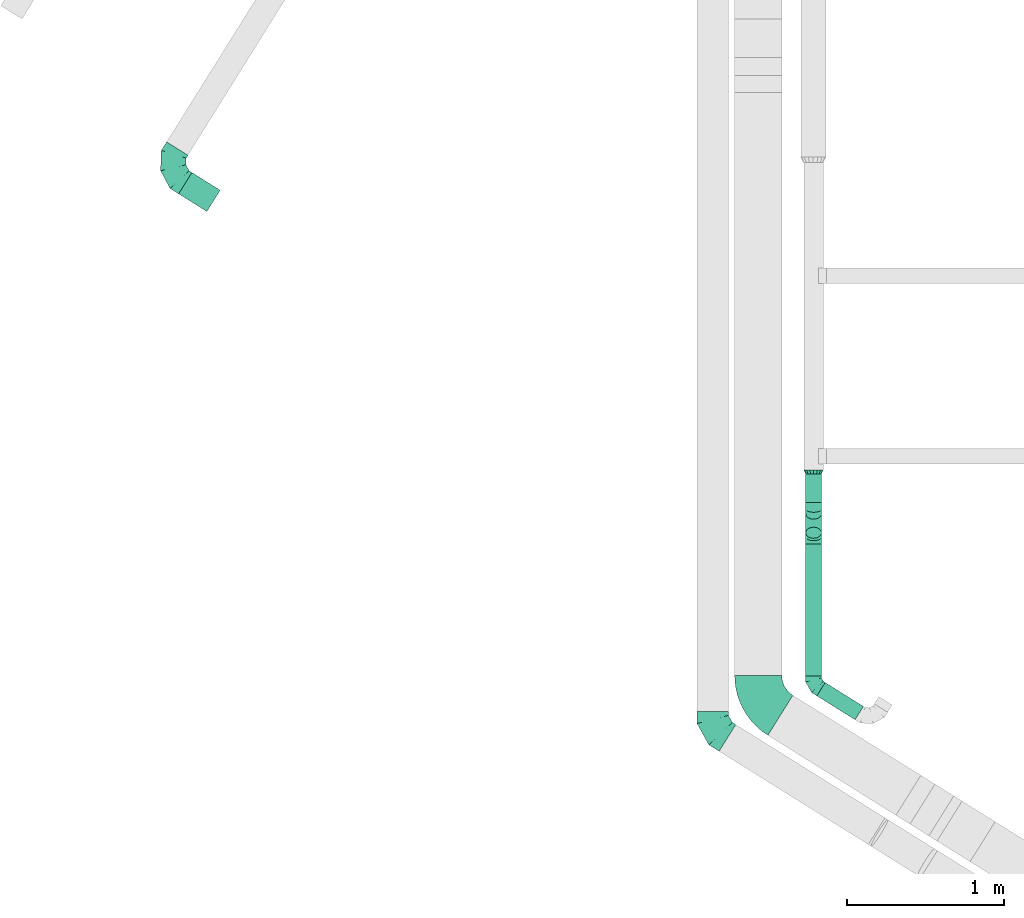
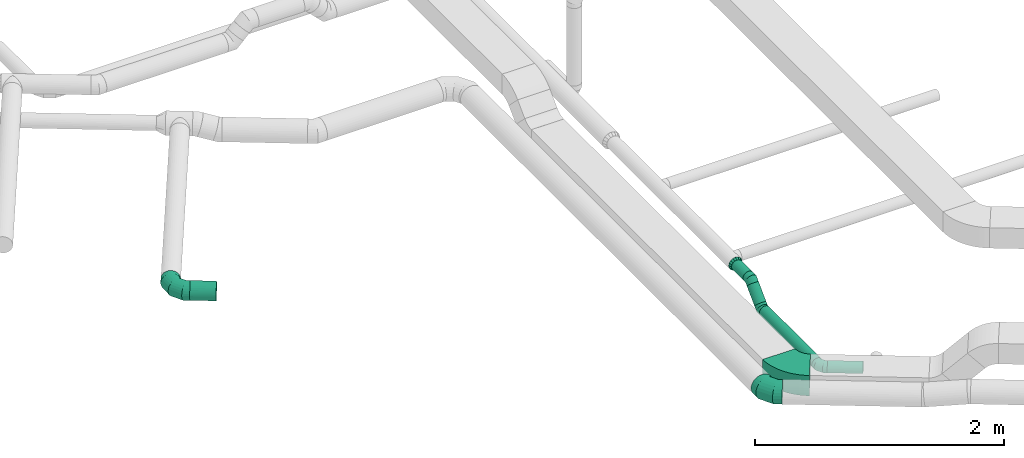
# One storey, part 4 of 60: 7 flow fittings, 5 flow segments.
"""IFC2X3 building model written with IfcOpenShell, lengths in millimetres."""

from ifc_helpers import new_model, entity, si_unit, converted_unit, derived_unit, direction, frame, frame_2d, origin, origin_2d_with_axis, place, context, subcontext, project, spatial, polyline, circle_curve, parameter, trimmed, segment, composite_curve, circle, outline, extrude, faceted_brep, source, transform, mapped, material, type_object, type_shapes, element, save


model = new_model("IFC2X3")

# Units and contexts
model_context = context("Model", 3, precision=0.01, world=origin(), true_north=direction((6.12303176911189e-17, 1.0)))
body_context = subcontext(model_context, "Body", "Model", "MODEL_VIEW")
ifc_project = project(units=[si_unit("LENGTHUNIT", "METRE", prefix="MILLI"), si_unit("AREAUNIT", "SQUARE_METRE"), si_unit("VOLUMEUNIT", "CUBIC_METRE"), converted_unit("PLANEANGLEUNIT", "DEGREE", entity("IfcRatioMeasure", 0.0174532925199433), si_unit("PLANEANGLEUNIT", "RADIAN"), dimensions=[0, 0, 0, 0, 0, 0, 0]), si_unit("MASSUNIT", "GRAM", prefix="KILO"), derived_unit("MASSDENSITYUNIT", [(si_unit("MASSUNIT", "GRAM", prefix="KILO"), 1), (si_unit("LENGTHUNIT", "METRE"), -3)]), derived_unit("MOMENTOFINERTIAUNIT", [(si_unit("LENGTHUNIT", "METRE"), 4)]), si_unit("TIMEUNIT", "SECOND"), si_unit("FREQUENCYUNIT", "HERTZ"), si_unit("THERMODYNAMICTEMPERATUREUNIT", "DEGREE_CELSIUS"), derived_unit("THERMALTRANSMITTANCEUNIT", [(si_unit("MASSUNIT", "GRAM", prefix="KILO"), 1), (si_unit("THERMODYNAMICTEMPERATUREUNIT", "KELVIN"), -1), (si_unit("TIMEUNIT", "SECOND"), -3)]), derived_unit("VOLUMETRICFLOWRATEUNIT", [(si_unit("LENGTHUNIT", "METRE"), 3), (si_unit("TIMEUNIT", "SECOND"), -1)]), derived_unit("MASSFLOWRATEUNIT", [(si_unit("MASSUNIT", "GRAM", prefix="KILO"), 1), (si_unit("TIMEUNIT", "SECOND"), -1)]), derived_unit("ROTATIONALFREQUENCYUNIT", [(si_unit("TIMEUNIT", "SECOND"), -1)]), si_unit("ELECTRICCURRENTUNIT", "AMPERE"), si_unit("ELECTRICVOLTAGEUNIT", "VOLT"), si_unit("POWERUNIT", "WATT"), si_unit("FORCEUNIT", "NEWTON", prefix="KILO"), si_unit("ILLUMINANCEUNIT", "LUX"), si_unit("LUMINOUSFLUXUNIT", "LUMEN"), si_unit("LUMINOUSINTENSITYUNIT", "CANDELA"), derived_unit("USERDEFINED", [(si_unit("MASSUNIT", "GRAM", prefix="KILO"), -1), (si_unit("LENGTHUNIT", "METRE"), -2), (si_unit("TIMEUNIT", "SECOND"), 3), (si_unit("LUMINOUSFLUXUNIT", "LUMEN"), 1)]), derived_unit("LINEARVELOCITYUNIT", [(si_unit("LENGTHUNIT", "METRE"), 1), (si_unit("TIMEUNIT", "SECOND"), -1)]), si_unit("PRESSUREUNIT", "PASCAL"), derived_unit("USERDEFINED", [(si_unit("LENGTHUNIT", "METRE"), -2), (si_unit("MASSUNIT", "GRAM", prefix="KILO"), 1), (si_unit("TIMEUNIT", "SECOND"), -2)]), derived_unit("LINEARFORCEUNIT", [(si_unit("MASSUNIT", "GRAM", prefix="KILO"), 1), (si_unit("LENGTHUNIT", "METRE"), 1), (si_unit("TIMEUNIT", "SECOND"), -2), (si_unit("LENGTHUNIT", "METRE"), -1)]), derived_unit("PLANARFORCEUNIT", [(si_unit("MASSUNIT", "GRAM", prefix="KILO"), 1), (si_unit("LENGTHUNIT", "METRE"), 1), (si_unit("TIMEUNIT", "SECOND"), -2), (si_unit("LENGTHUNIT", "METRE"), -2)])], contexts=[model_context])

# Site, building, storey
site_placement = place(None, origin())
site = spatial("IfcSite", under=ifc_project, at=site_placement, CompositionType="ELEMENT")
building_placement = place(site_placement, origin())
building = spatial("IfcBuilding", under=site, at=building_placement, CompositionType="ELEMENT")
storey_placement = place(building_placement, frame((0.0, 0.0, 19800.0)))
storey = spatial("IfcBuildingStorey", under=building, at=storey_placement, CompositionType="ELEMENT", Elevation=19800.0)

# Flow segments
duct_segment_type = type_object("IfcDuctSegmentType", PredefinedType="NOTDEFINED")
flow_segment_1_placement = place(storey_placement, frame((16951.05, 3539.05, 2988.4)))
element("IfcFlowSegment", 1, at=flow_segment_1_placement, inside=storey, type_object=duct_segment_type, context=body_context, shape_type="SweptSolid", body=[
    extrude(circle(Radius=50.0, at=origin_2d_with_axis()), frame((51.6, 0.0, 51.6), z_axis=(0.0, 1.0, 0.0), x_axis=(-1.0, 0.0, 0.0)), (0.0, 0.0, 1.0), 840.2093082432),
])
flow_segment_2_placement = place(storey_placement, frame((17021.57, 3257.99, 2988.4)))
element("IfcFlowSegment", 2, at=flow_segment_2_placement, inside=storey, type_object=duct_segment_type, context=body_context, shape_type="SweptSolid", body=[
    extrude(circle(Radius=50.0, at=origin_2d_with_axis()), frame((271.75, 44.0, 51.6), z_axis=(-0.848052743777585, 0.529911826412008, 0.0), x_axis=(-0.529911826412008, -0.848052743777585, 0.0)), (0.0, 0.0, 1.0), 287.312124453277),
])
flow_segment_3_placement = place(storey_placement, frame((16951.05, 4413.02, 3032.34)))
element("IfcFlowSegment", 3, at=flow_segment_3_placement, inside=storey, type_object=duct_segment_type, context=body_context, shape_type="SweptSolid", body=[
    extrude(circle(Radius=50.0, at=origin_2d_with_axis()), frame((51.6, 36.95, 36.95), z_axis=(0.0, 0.707106781186553, 0.707106781186542), x_axis=(1.0, 0.0, 0.0)), (0.0, 0.0, 1.0), 171.715728752511),
])
flow_segment_4_placement = place(storey_placement, frame((16951.05, 4642.1, 3168.4)))
element("IfcFlowSegment", 4, at=flow_segment_4_placement, inside=storey, type_object=duct_segment_type, context=body_context, shape_type="SweptSolid", body=[
    extrude(circle(Radius=50.0, at=origin_2d_with_axis()), frame((51.6, 0.0, 51.6), z_axis=(0.0, 1.0, 0.0), x_axis=(-1.0, 0.0, 0.0)), (0.0, 0.0, 1.0), 183.078643762733),
])
flow_segment_5_placement = place(storey_placement, frame((12959.43, 6493.1, 3168.4)))
element("IfcFlowSegment", 5, at=flow_segment_5_placement, inside=storey, type_object=duct_segment_type, context=body_context, shape_type="SweptSolid", body=[
    extrude(circle(Radius=80.0, at=origin_2d_with_axis()), frame((43.99, 181.83, 81.6), z_axis=(0.84805274377758, -0.529911826412016, 0.0), x_axis=(-0.529911826412016, -0.84805274377758, 0.0)), (0.0, 0.0, 1.0), 212.089328759062),
])

# Flow fittings
ifc_material = material()
duct_fitting_type_1 = type_object("IfcDuctFittingType", PredefinedType="NOTDEFINED", material=ifc_material)
shared_shape_1 = source(origin(), body_context, "Body", "Brep", [
    faceted_brep([(-160.0, 0.0, -80.0), (-160.0, -20.71, -77.27), (-160.0, -40.0, -69.28), (-160.0, -56.57, -56.57), (-160.0, -69.28, -40.0), (-160.0, -77.27, -20.71), (-160.0, -80.0, 0.0), (-160.0, -77.27, 20.71), (-160.0, -69.28, 40.0), (-160.0, -56.57, 56.57), (-160.0, -40.0, 69.28), (-160.0, -20.71, 77.27), (-160.0, 0.0, 80.0), (-160.0, 20.71, 77.27), (-160.0, 40.0, 69.28), (-160.0, 56.57, 56.57), (-160.0, 69.28, 40.0), (-160.0, 77.27, 20.71), (-160.0, 80.0, 0.0), (-160.0, 77.27, -20.71), (-160.0, 69.28, -40.0), (-160.0, 56.57, -56.57), (-160.0, 40.0, -69.28), (-160.0, 20.71, -77.27), (-122.68, 20.71, 77.27), (-127.85, 40.0, 69.28), (-117.13, 0.0, 80.0), (-132.29, 56.57, 56.57), (-137.83, 77.27, 20.71), (-138.56, 80.0, 0.0), (-135.69, 69.28, 40.0), (-135.69, 69.28, -40.0), (-132.29, 56.57, -56.57), (-137.83, 77.27, -20.71), (-122.68, 20.71, -77.27), (-117.13, 0.0, -80.0), (-127.85, 40.0, -69.28), (-111.58, -20.71, -77.27), (-106.41, -40.0, -69.28), (-101.97, -56.57, -56.57), (-98.56, -69.28, -40.0), (-96.42, -77.27, -20.71), (-95.69, -80.0, 0.0), (-96.42, -77.27, 20.71), (-98.56, -69.28, 40.0), (-101.97, -56.57, 56.57), (-106.41, -40.0, 69.28), (-111.58, -20.71, 77.27), (-58.03, 58.03, 77.27), (-72.15, 72.15, 69.28), (-42.87, 42.87, 80.0), (-84.28, 84.28, 56.57), (-93.59, 93.59, 40.0), (-99.44, 99.44, 20.71), (-101.44, 101.44, 0.0), (-99.44, 99.44, -20.71), (-93.59, 93.59, -40.0), (-84.28, 84.28, -56.57), (-58.03, 58.03, -77.27), (-42.87, 42.87, -80.0), (-72.15, 72.15, -69.28), (-27.71, 27.71, -77.27), (-13.59, 13.59, -69.28), (-1.46, 1.46, -56.57), (7.85, -7.85, -40.0), (13.7, -13.7, -20.71), (15.69, -15.69, 0.0), (13.7, -13.7, 20.71), (7.85, -7.85, 40.0), (-1.46, 1.46, 56.57), (-13.59, 13.59, 69.28), (-27.71, 27.71, 77.27), (-20.71, 122.68, 77.27), (-40.0, 127.85, 69.28), (0.0, 117.13, 80.0), (-56.57, 132.29, 56.57), (-69.28, 135.69, 40.0), (-77.27, 137.83, 20.71), (-80.0, 138.56, 0.0), (-77.27, 137.83, -20.71), (-69.28, 135.69, -40.0), (-56.57, 132.29, -56.57), (-20.71, 122.68, -77.27), (0.0, 117.13, -80.0), (-40.0, 127.85, -69.28), (20.71, 111.58, -77.27), (40.0, 106.41, -69.28), (56.57, 101.97, -56.57), (69.28, 98.56, -40.0), (77.27, 96.42, -20.71), (80.0, 95.69, 0.0), (77.27, 96.42, 20.71), (69.28, 98.56, 40.0), (56.57, 101.97, 56.57), (40.0, 106.41, 69.28), (20.71, 111.58, 77.27), (-20.71, 160.0, -77.27), (-40.0, 160.0, -69.28), (-56.57, 160.0, -56.57), (-69.28, 160.0, -40.0), (-77.27, 160.0, -20.71), (-80.0, 160.0, 0.0), (-77.27, 160.0, 20.71), (-69.28, 160.0, 40.0), (-56.57, 160.0, 56.57), (-40.0, 160.0, 69.28), (-20.71, 160.0, 77.27), (0.0, 160.0, 80.0), (20.71, 160.0, 77.27), (40.0, 160.0, 69.28), (56.57, 160.0, 56.57), (69.28, 160.0, 40.0), (77.27, 160.0, 20.71), (80.0, 160.0, 0.0), (77.27, 160.0, -20.71), (69.28, 160.0, -40.0), (56.57, 160.0, -56.57), (40.0, 160.0, -69.28), (20.71, 160.0, -77.27), (0.0, 160.0, -80.0)], [[[0, 1, 2, 3, 4, 5, 6, 7, 8, 9, 10, 11, 12, 13, 14, 15, 16, 17, 18, 19, 20, 21, 22, 23]], [[24, 25, 14, 13]], [[26, 24, 13, 12]], [[14, 25, 27, 15]], [[28, 29, 18, 17]], [[30, 28, 17, 16]], [[15, 27, 30, 16]], [[20, 31, 32, 21]], [[33, 31, 20, 19]], [[18, 29, 33, 19]], [[34, 35, 0, 23]], [[36, 34, 23, 22]], [[32, 36, 22, 21]], [[1, 0, 35, 37]], [[2, 1, 37, 38]], [[3, 2, 38, 39]], [[5, 4, 40, 41]], [[6, 5, 41, 42]], [[39, 40, 4, 3]], [[6, 42, 43, 7]], [[7, 43, 44, 8]], [[8, 44, 45, 9]], [[9, 45, 46, 10]], [[10, 46, 47, 11]], [[26, 12, 11, 47]], [[48, 49, 25, 24]], [[50, 48, 24, 26]], [[27, 25, 49, 51]], [[52, 53, 28, 30]], [[51, 52, 30, 27]], [[29, 28, 53, 54]], [[55, 56, 31, 33]], [[54, 55, 33, 29]], [[32, 31, 56, 57]], [[58, 59, 35, 34]], [[60, 58, 34, 36]], [[57, 60, 36, 32]], [[37, 35, 59, 61]], [[38, 37, 61, 62]], [[39, 38, 62, 63]], [[41, 40, 64, 65]], [[42, 41, 65, 66]], [[63, 64, 40, 39]], [[43, 42, 66, 67]], [[44, 43, 67, 68]], [[68, 69, 45, 44]], [[46, 45, 69, 70]], [[47, 46, 70, 71]], [[26, 47, 71, 50]], [[72, 73, 49, 48]], [[74, 72, 48, 50]], [[51, 49, 73, 75]], [[76, 77, 53, 52]], [[75, 76, 52, 51]], [[54, 53, 77, 78]], [[79, 80, 56, 55]], [[78, 79, 55, 54]], [[57, 56, 80, 81]], [[82, 83, 59, 58]], [[84, 82, 58, 60]], [[81, 84, 60, 57]], [[61, 59, 83, 85]], [[62, 61, 85, 86]], [[63, 62, 86, 87]], [[65, 64, 88, 89]], [[66, 65, 89, 90]], [[87, 88, 64, 63]], [[67, 66, 90, 91]], [[68, 67, 91, 92]], [[92, 93, 69, 68]], [[70, 69, 93, 94]], [[71, 70, 94, 95]], [[50, 71, 95, 74]], [[96, 97, 98, 99, 100, 101, 102, 103, 104, 105, 106, 107, 108, 109, 110, 111, 112, 113, 114, 115, 116, 117, 118, 119]], [[72, 74, 107, 106]], [[73, 72, 106, 105]], [[75, 73, 105, 104]], [[77, 76, 103, 102]], [[78, 77, 102, 101]], [[75, 104, 103, 76]], [[78, 101, 100, 79]], [[79, 100, 99, 80]], [[80, 99, 98, 81]], [[84, 97, 96, 82]], [[82, 96, 119, 83]], [[84, 81, 98, 97]], [[118, 117, 86, 85]], [[119, 118, 85, 83]], [[116, 87, 86, 117]], [[88, 115, 114, 89]], [[89, 114, 113, 90]], [[115, 88, 87, 116]], [[112, 111, 92, 91]], [[113, 112, 91, 90]], [[111, 110, 93, 92]], [[95, 94, 109, 108]], [[74, 95, 108, 107]], [[110, 109, 94, 93]]]),
])
type_shapes(duct_fitting_type_1, [shared_shape_1])
flow_fitting_1_placement = place(storey_placement, frame((12867.73, 6759.71, 3250.0), z_axis=(0.0, 0.0, 1.0), x_axis=(-0.52991182641202, -0.848052743777577, 0.0)))
element("IfcFlowFitting", 6, at=flow_fitting_1_placement, inside=storey, type_object=duct_fitting_type_1, material=ifc_material, context=body_context, shape_type="MappedRepresentation", body=[
    mapped(shared_shape_1, transform((0.0, 0.0, 0.0), scale=1.0)),
])
duct_fitting_type_2 = type_object("IfcDuctFittingType", PredefinedType="NOTDEFINED", material=ifc_material)
shared_shape_2 = source(origin(), body_context, "Body", "Brep", [
    faceted_brep([(-41.42, 0.0, -50.0), (-41.42, -12.94, -48.3), (-41.42, -25.0, -43.3), (-41.42, -35.36, -35.36), (-41.42, -43.3, -25.0), (-41.42, -48.3, -12.94), (-41.42, -50.0, 0.0), (-41.42, -48.3, 12.94), (-41.42, -43.3, 25.0), (-41.42, -35.36, 35.36), (-41.42, -25.0, 43.3), (-41.42, -12.94, 48.3), (-41.42, 0.0, 50.0), (-41.42, 12.94, 48.3), (-41.42, 25.0, 43.3), (-41.42, 35.36, 35.36), (-41.42, 43.3, 25.0), (-41.42, 48.3, 12.94), (-41.42, 50.0, 0.0), (-41.42, 48.3, -12.94), (-41.42, 43.3, -25.0), (-41.42, 35.36, -35.36), (-41.42, 25.0, -43.3), (-41.42, 12.94, -48.3), (-5.36, 12.94, 48.3), (-10.36, 25.0, 43.3), (0.0, 0.0, 50.0), (-14.64, 35.36, 35.36), (-20.0, 48.3, 12.94), (-20.71, 50.0, 0.0), (-17.94, 43.3, 25.0), (-17.94, 43.3, -25.0), (-14.64, 35.36, -35.36), (-20.0, 48.3, -12.94), (-5.36, 12.94, -48.3), (0.0, 0.0, -50.0), (-10.36, 25.0, -43.3), (5.36, -12.94, -48.3), (10.36, -25.0, -43.3), (14.64, -35.36, -35.36), (17.94, -43.3, -25.0), (20.0, -48.3, -12.94), (20.71, -50.0, 0.0), (20.0, -48.3, 12.94), (17.94, -43.3, 25.0), (14.64, -35.36, 35.36), (10.36, -25.0, 43.3), (5.36, -12.94, 48.3), (29.29, 29.29, 50.0), (20.14, 38.44, 48.3), (11.61, 46.97, 43.3), (4.29, 54.29, 35.36), (-1.33, 59.91, 25.0), (-4.86, 63.44, 12.94), (-6.07, 64.64, 0.0), (-4.86, 63.44, -12.94), (-1.33, 59.91, -25.0), (4.29, 54.29, -35.36), (11.61, 46.97, -43.3), (20.14, 38.44, -48.3), (29.29, 29.29, -50.0), (38.44, 20.14, -48.3), (46.97, 11.61, -43.3), (54.29, 4.29, -35.36), (59.91, -1.33, -25.0), (63.44, -4.86, -12.94), (64.64, -6.07, 0.0), (63.44, -4.86, 12.94), (59.91, -1.33, 25.0), (54.29, 4.29, 35.36), (46.97, 11.61, 43.3), (38.44, 20.14, 48.3)], [[[0, 1, 2, 3, 4, 5, 6, 7, 8, 9, 10, 11, 12, 13, 14, 15, 16, 17, 18, 19, 20, 21, 22, 23]], [[24, 25, 14, 13]], [[26, 24, 13, 12]], [[14, 25, 27, 15]], [[28, 29, 18, 17]], [[30, 28, 17, 16]], [[16, 15, 27, 30]], [[20, 31, 32, 21]], [[33, 31, 20, 19]], [[18, 29, 33, 19]], [[34, 35, 0, 23]], [[36, 34, 23, 22]], [[32, 36, 22, 21]], [[1, 0, 35, 37]], [[2, 1, 37, 38]], [[38, 39, 3, 2]], [[5, 4, 40, 41]], [[6, 5, 41, 42]], [[39, 40, 4, 3]], [[6, 42, 43, 7]], [[7, 43, 44, 8]], [[8, 44, 45, 9]], [[9, 45, 46, 10]], [[10, 46, 47, 11]], [[26, 12, 11, 47]], [[24, 26, 48, 49]], [[25, 24, 49, 50]], [[27, 25, 50, 51]], [[28, 30, 52, 53]], [[29, 28, 53, 54]], [[27, 51, 52, 30]], [[29, 54, 55, 33]], [[33, 55, 56, 31]], [[31, 56, 57, 32]], [[36, 58, 59, 34]], [[34, 59, 60, 35]], [[36, 32, 57, 58]], [[61, 62, 38, 37]], [[60, 61, 37, 35]], [[63, 39, 38, 62]], [[40, 64, 65, 41]], [[41, 65, 66, 42]], [[64, 40, 39, 63]], [[43, 42, 66, 67]], [[44, 43, 67, 68]], [[68, 69, 45, 44]], [[47, 46, 70, 71]], [[26, 47, 71, 48]], [[69, 70, 46, 45]], [[59, 58, 57, 56, 55, 54, 53, 52, 51, 50, 49, 48, 71, 70, 69, 68, 67, 66, 65, 64, 63, 62, 61, 60]]]),
])
type_shapes(duct_fitting_type_2, [shared_shape_2])
for number, where, z_axis, x_axis in (
    (7, (17002.65, 4420.68, 3040.0), (1.0, 0.0, 0.0), (0.0, 1.0, 0.0)),
    (8, (17002.65, 4600.68, 3220.0), (-1.0, 0.0, 0.0), (0.0, 0.707106781186472, 0.707106781186623)),
):
    element("IfcFlowFitting", number, at=place(storey_placement, frame(where, z_axis=z_axis, x_axis=x_axis)), inside=storey, type_object=duct_fitting_type_2, material=ifc_material, context=body_context, shape_type="MappedRepresentation", body=[
        mapped(shared_shape_2, transform((0.0, 0.0, 0.0), scale=1.0)),
    ])
duct_fitting_type_3 = type_object("IfcDuctFittingType", PredefinedType="NOTDEFINED", material=ifc_material)
shared_shape_3 = source(origin(), body_context, "Body", "Brep", [
    faceted_brep([(25.0, -46.19, 19.13), (25.0, -48.1, 9.57), (25.0, -50.0, 0.0), (25.0, -48.1, -9.57), (25.0, -46.19, -19.13), (25.0, -40.77, -27.24), (25.0, -35.36, -35.36), (25.0, -27.24, -40.77), (25.0, -19.13, -46.19), (25.0, -9.57, -48.1), (25.0, 0.0, -50.0), (25.0, 9.57, -48.1), (25.0, 19.13, -46.19), (25.0, 27.24, -40.77), (25.0, 35.36, -35.36), (25.0, 40.77, -27.24), (25.0, 46.19, -19.13), (25.0, 48.1, -9.57), (25.0, 50.0, 0.0), (25.0, 48.1, 9.57), (25.0, 46.19, 19.13), (25.0, 40.77, 27.24), (25.0, 35.36, 35.36), (25.0, 27.24, 40.77), (25.0, 19.13, 46.19), (25.0, 9.57, 48.1), (25.0, 0.0, 50.0), (25.0, -9.57, 48.1), (25.0, -19.13, 46.19), (25.0, -27.24, 40.77), (25.0, -35.36, 35.36), (25.0, -40.77, 27.24), (0.0, -62.5, 0.0), (0.0, -60.02, 12.45), (0.0, -57.74, 23.92), (0.0, -50.97, 34.06), (0.0, -44.19, 44.19), (0.0, -34.06, 50.97), (0.0, -23.92, 57.74), (0.0, -12.45, 60.02), (0.0, 0.0, 62.5), (0.0, 12.45, 60.02), (0.0, 23.92, 57.74), (0.0, 34.06, 50.97), (0.0, 44.19, 44.19), (0.0, 50.97, 34.06), (0.0, 57.74, 23.92), (0.0, 60.02, 12.45), (0.0, 62.5, 0.0), (0.0, 60.02, -12.45), (0.0, 57.74, -23.92), (0.0, 50.97, -34.06), (0.0, 44.19, -44.19), (0.0, 34.06, -50.97), (0.0, 23.92, -57.74), (0.0, 12.45, -60.02), (0.0, 0.0, -62.5), (0.0, -12.45, -60.02), (0.0, -23.92, -57.74), (0.0, -34.06, -50.97), (0.0, -44.19, -44.19), (0.0, -50.97, -34.06), (0.0, -57.74, -23.92), (0.0, -60.02, -12.45)], [[[0, 1, 2, 3, 4, 5, 6, 7, 8, 9, 10, 11, 12, 13, 14, 15, 16, 17, 18, 19, 20, 21, 22, 23, 24, 25, 26, 27, 28, 29, 30, 31]], [[32, 33, 34, 35, 36, 37, 38, 39, 40, 41, 42, 43, 44, 45, 46, 47, 48, 49, 50, 51, 52, 53, 54, 55, 56, 57, 58, 59, 60, 61, 62, 63]], [[24, 42, 41, 40, 26, 25]], [[22, 44, 43, 42, 24, 23]], [[48, 47, 46, 20, 19, 18]], [[44, 22, 21, 20, 46, 45]], [[0, 34, 33, 32, 2, 1]], [[30, 36, 35, 34, 0, 31]], [[40, 39, 38, 28, 27, 26]], [[36, 30, 29, 28, 38, 37]], [[8, 58, 57, 56, 10, 9]], [[6, 60, 59, 58, 8, 7]], [[32, 63, 62, 4, 3, 2]], [[60, 6, 5, 4, 62, 61]], [[16, 50, 49, 48, 18, 17]], [[14, 52, 51, 50, 16, 15]], [[56, 55, 54, 12, 11, 10]], [[52, 14, 13, 12, 54, 53]]]),
])
type_shapes(duct_fitting_type_3, [shared_shape_3])
flow_fitting_2_placement = place(storey_placement, frame((17002.65, 4850.18, 3220.0), z_axis=(0.0, 0.0, 1.0), x_axis=(0.0, -1.0, 0.0)))
element("IfcFlowFitting", 9, at=flow_fitting_2_placement, inside=storey, type_object=duct_fitting_type_3, material=ifc_material, context=body_context, shape_type="MappedRepresentation", body=[
    mapped(shared_shape_3, transform((0.0, 0.0, 0.0), scale=1.0)),
])
duct_fitting_type_4 = type_object("IfcDuctFittingType", PredefinedType="NOTDEFINED", material=ifc_material)
shared_shape_4 = source(origin(), body_context, "Body", "Brep", [
    faceted_brep([(-110.86, 0.0, -100.0), (-110.86, -25.88, -96.59), (-110.86, -50.0, -86.6), (-110.86, -70.71, -70.71), (-110.86, -86.6, -50.0), (-110.86, -96.59, -25.88), (-110.86, -100.0, 0.0), (-110.86, -96.59, 25.88), (-110.86, -86.6, 50.0), (-110.86, -70.71, 70.71), (-110.86, -50.0, 86.6), (-110.86, -25.88, 96.59), (-110.86, 0.0, 100.0), (-110.86, 25.88, 96.59), (-110.86, 50.0, 86.6), (-110.86, 70.71, 70.71), (-110.86, 86.6, 50.0), (-110.86, 96.59, 25.88), (-110.86, 100.0, 0.0), (-110.86, 96.59, -25.88), (-110.86, 86.6, -50.0), (-110.86, 70.71, -70.71), (-110.86, 50.0, -86.6), (-110.86, 25.88, -96.59), (-65.83, 25.88, 96.59), (-72.07, 50.0, 86.6), (-59.14, 0.0, 100.0), (-77.43, 70.71, 70.71), (-84.12, 96.59, 25.88), (-85.0, 100.0, 0.0), (-81.54, 86.6, 50.0), (-81.54, 86.6, -50.0), (-77.43, 70.71, -70.71), (-84.12, 96.59, -25.88), (-65.83, 25.88, -96.59), (-59.14, 0.0, -100.0), (-72.07, 50.0, -86.6), (-52.45, -25.88, -96.59), (-46.21, -50.0, -86.6), (-40.85, -70.71, -70.71), (-36.74, -86.6, -50.0), (-34.16, -96.59, -25.88), (-33.28, -100.0, 0.0), (-34.16, -96.59, 25.88), (-36.74, -86.6, 50.0), (-40.85, -70.71, 70.71), (-46.21, -50.0, 86.6), (-52.45, -25.88, 96.59), (12.94, 69.54, 96.59), (-4.21, 87.61, 86.6), (31.34, 50.15, 100.0), (-18.94, 103.13, 70.71), (-30.24, 115.04, 50.0), (-37.34, 122.52, 25.88), (-39.76, 125.08, 0.0), (-37.34, 122.52, -25.88), (-30.24, 115.04, -50.0), (-18.94, 103.13, -70.71), (12.94, 69.54, -96.59), (31.34, 50.15, -100.0), (-4.21, 87.61, -86.6), (49.74, 30.76, -96.59), (66.89, 12.69, -86.6), (81.61, -2.83, -70.71), (92.91, -14.73, -50.0), (100.02, -22.22, -25.88), (102.44, -24.77, 0.0), (100.02, -22.22, 25.88), (92.91, -14.73, 50.0), (81.61, -2.83, 70.71), (66.89, 12.69, 86.6), (49.74, 30.76, 96.59), (58.75, 94.02, 100.0), (36.8, 107.73, 96.59), (16.34, 120.51, 86.6), (-1.22, 131.49, 70.71), (-14.7, 139.91, 50.0), (-23.17, 145.2, 25.88), (-26.06, 147.01, 0.0), (-23.17, 145.2, -25.88), (-14.7, 139.91, -50.0), (-1.22, 131.49, -70.71), (16.34, 120.51, -86.6), (36.8, 107.73, -96.59), (58.75, 94.02, -100.0), (80.7, 80.3, -96.59), (101.15, 67.52, -86.6), (118.71, 56.55, -70.71), (132.19, 48.13, -50.0), (140.66, 42.83, -25.88), (143.55, 41.03, 0.0), (140.66, 42.83, 25.88), (132.19, 48.13, 50.0), (118.71, 56.55, 70.71), (101.15, 67.52, 86.6), (80.7, 80.3, 96.59)], [[[0, 1, 2, 3, 4, 5, 6, 7, 8, 9, 10, 11, 12, 13, 14, 15, 16, 17, 18, 19, 20, 21, 22, 23]], [[24, 25, 14, 13]], [[26, 24, 13, 12]], [[14, 25, 27, 15]], [[28, 29, 18, 17]], [[30, 28, 17, 16]], [[15, 27, 30, 16]], [[20, 31, 32, 21]], [[33, 31, 20, 19]], [[18, 29, 33, 19]], [[34, 35, 0, 23]], [[36, 34, 23, 22]], [[32, 36, 22, 21]], [[1, 0, 35, 37]], [[2, 1, 37, 38]], [[38, 39, 3, 2]], [[5, 4, 40, 41]], [[6, 5, 41, 42]], [[39, 40, 4, 3]], [[6, 42, 43, 7]], [[7, 43, 44, 8]], [[8, 44, 45, 9]], [[9, 45, 46, 10]], [[10, 46, 47, 11]], [[26, 12, 11, 47]], [[48, 49, 25, 24]], [[50, 48, 24, 26]], [[27, 25, 49, 51]], [[52, 53, 28, 30]], [[51, 52, 30, 27]], [[29, 28, 53, 54]], [[55, 56, 31, 33]], [[54, 55, 33, 29]], [[32, 31, 56, 57]], [[58, 59, 35, 34]], [[60, 58, 34, 36]], [[57, 60, 36, 32]], [[37, 35, 59, 61]], [[38, 37, 61, 62]], [[39, 38, 62, 63]], [[41, 40, 64, 65]], [[42, 41, 65, 66]], [[63, 64, 40, 39]], [[43, 42, 66, 67]], [[44, 43, 67, 68]], [[68, 69, 45, 44]], [[46, 45, 69, 70]], [[47, 46, 70, 71]], [[26, 47, 71, 50]], [[48, 50, 72, 73]], [[49, 48, 73, 74]], [[51, 49, 74, 75]], [[53, 52, 76, 77]], [[54, 53, 77, 78]], [[51, 75, 76, 52]], [[54, 78, 79, 55]], [[55, 79, 80, 56]], [[56, 80, 81, 57]], [[60, 82, 83, 58]], [[58, 83, 84, 59]], [[60, 57, 81, 82]], [[85, 86, 62, 61]], [[84, 85, 61, 59]], [[87, 63, 62, 86]], [[64, 88, 89, 65]], [[65, 89, 90, 66]], [[88, 64, 63, 87]], [[67, 66, 90, 91]], [[68, 67, 91, 92]], [[92, 93, 69, 68]], [[71, 70, 94, 95]], [[50, 71, 95, 72]], [[93, 94, 70, 69]], [[83, 82, 81, 80, 79, 78, 77, 76, 75, 74, 73, 72, 95, 94, 93, 92, 91, 90, 89, 88, 87, 86, 85, 84]]]),
])
type_shapes(duct_fitting_type_4, [shared_shape_4])
flow_fitting_3_placement = place(storey_placement, frame((16360.54, 3202.5, 3190.0), z_axis=(0.0, 0.0, 1.0), x_axis=(0.0, -1.0, 0.0)))
element("IfcFlowFitting", 10, at=flow_fitting_3_placement, inside=storey, type_object=duct_fitting_type_4, material=ifc_material, context=body_context, shape_type="MappedRepresentation", body=[
    mapped(shared_shape_4, transform((0.0, 0.0, 0.0), scale=1.0)),
])
duct_fitting_type_5 = type_object("IfcDuctFittingType", PredefinedType="NOTDEFINED", material=ifc_material)
shared_shape_5 = source(origin(), body_context, "Body", "Brep", [
    faceted_brep([(-55.43, 0.0, -50.0), (-55.43, -12.94, -48.3), (-55.43, -25.0, -43.3), (-55.43, -35.36, -35.36), (-55.43, -43.3, -25.0), (-55.43, -48.3, -12.94), (-55.43, -50.0, 0.0), (-55.43, -48.3, 12.94), (-55.43, -43.3, 25.0), (-55.43, -35.36, 35.36), (-55.43, -25.0, 43.3), (-55.43, -12.94, 48.3), (-55.43, 0.0, 50.0), (-55.43, 12.94, 48.3), (-55.43, 25.0, 43.3), (-55.43, 35.36, 35.36), (-55.43, 43.3, 25.0), (-55.43, 48.3, 12.94), (-55.43, 50.0, 0.0), (-55.43, 48.3, -12.94), (-55.43, 43.3, -25.0), (-55.43, 35.36, -35.36), (-55.43, 25.0, -43.3), (-55.43, 12.94, -48.3), (-32.92, 12.94, 48.3), (-36.03, 25.0, 43.3), (-29.57, 0.0, 50.0), (-38.71, 35.36, 35.36), (-42.06, 48.3, 12.94), (-42.5, 50.0, 0.0), (-40.77, 43.3, 25.0), (-40.77, 43.3, -25.0), (-38.71, 35.36, -35.36), (-42.06, 48.3, -12.94), (-32.92, 12.94, -48.3), (-29.57, 0.0, -50.0), (-36.03, 25.0, -43.3), (-26.22, -12.94, -48.3), (-23.1, -25.0, -43.3), (-20.43, -35.36, -35.36), (-18.37, -43.3, -25.0), (-17.08, -48.3, -12.94), (-16.64, -50.0, 0.0), (-17.08, -48.3, 12.94), (-18.37, -43.3, 25.0), (-20.43, -35.36, 35.36), (-23.1, -25.0, 43.3), (-26.22, -12.94, 48.3), (6.47, 34.77, 48.3), (-2.11, 43.81, 43.3), (15.67, 25.08, 50.0), (-9.47, 51.57, 35.36), (-15.12, 57.52, 25.0), (-18.67, 61.26, 12.94), (-19.88, 62.54, 0.0), (-18.67, 61.26, -12.94), (-15.12, 57.52, -25.0), (-9.47, 51.57, -35.36), (6.47, 34.77, -48.3), (15.67, 25.08, -50.0), (-2.11, 43.81, -43.3), (24.87, 15.38, -48.3), (33.44, 6.35, -43.3), (40.81, -1.41, -35.36), (46.46, -7.37, -25.0), (50.01, -11.11, -12.94), (51.22, -12.39, 0.0), (50.01, -11.11, 12.94), (46.46, -7.37, 25.0), (40.81, -1.41, 35.36), (33.44, 6.35, 43.3), (24.87, 15.38, 48.3), (29.37, 47.01, 50.0), (18.4, 53.87, 48.3), (8.17, 60.26, 43.3), (-0.61, 65.74, 35.36), (-7.35, 69.95, 25.0), (-11.58, 72.6, 12.94), (-13.03, 73.5, 0.0), (-11.58, 72.6, -12.94), (-7.35, 69.95, -25.0), (-0.61, 65.74, -35.36), (18.4, 53.87, -48.3), (29.37, 47.01, -50.0), (8.17, 60.26, -43.3), (40.35, 40.15, -48.3), (50.58, 33.76, -43.3), (59.36, 28.27, -35.36), (66.1, 24.06, -25.0), (70.33, 21.42, -12.94), (71.78, 20.51, 0.0), (70.33, 21.42, 12.94), (66.1, 24.06, 25.0), (59.36, 28.27, 35.36), (40.35, 40.15, 48.3), (50.58, 33.76, 43.3)], [[[0, 1, 2, 3, 4, 5, 6, 7, 8, 9, 10, 11, 12, 13, 14, 15, 16, 17, 18, 19, 20, 21, 22, 23]], [[24, 25, 14, 13]], [[26, 24, 13, 12]], [[14, 25, 27, 15]], [[28, 29, 18, 17]], [[30, 28, 17, 16]], [[15, 27, 30, 16]], [[20, 31, 32, 21]], [[33, 31, 20, 19]], [[18, 29, 33, 19]], [[34, 35, 0, 23]], [[36, 34, 23, 22]], [[32, 36, 22, 21]], [[2, 1, 37, 38]], [[3, 2, 38, 39]], [[0, 35, 37, 1]], [[5, 4, 40, 41]], [[6, 5, 41, 42]], [[3, 39, 40, 4]], [[6, 42, 43, 7]], [[7, 43, 44, 8]], [[8, 44, 45, 9]], [[10, 46, 47, 11]], [[11, 47, 26, 12]], [[9, 45, 46, 10]], [[48, 49, 25, 24]], [[50, 48, 24, 26]], [[27, 25, 49, 51]], [[52, 53, 28, 30]], [[51, 52, 30, 27]], [[29, 28, 53, 54]], [[55, 56, 31, 33]], [[54, 55, 33, 29]], [[57, 32, 31, 56]], [[58, 59, 35, 34]], [[60, 58, 34, 36]], [[57, 60, 36, 32]], [[37, 35, 59, 61]], [[38, 37, 61, 62]], [[39, 38, 62, 63]], [[41, 40, 64, 65]], [[42, 41, 65, 66]], [[63, 64, 40, 39]], [[43, 42, 66, 67]], [[44, 43, 67, 68]], [[68, 69, 45, 44]], [[46, 45, 69, 70]], [[47, 46, 70, 71]], [[26, 47, 71, 50]], [[48, 50, 72, 73]], [[49, 48, 73, 74]], [[51, 49, 74, 75]], [[53, 52, 76, 77]], [[54, 53, 77, 78]], [[51, 75, 76, 52]], [[54, 78, 79, 55]], [[55, 79, 80, 56]], [[56, 80, 81, 57]], [[82, 83, 59, 58]], [[84, 82, 58, 60]], [[60, 57, 81, 84]], [[59, 83, 85, 61]], [[61, 85, 86, 62]], [[62, 86, 87, 63]], [[64, 88, 89, 65]], [[65, 89, 90, 66]], [[63, 87, 88, 64]], [[67, 66, 90, 91]], [[68, 67, 91, 92]], [[69, 68, 92, 93]], [[94, 72, 50, 71]], [[95, 94, 71, 70]], [[93, 95, 70, 69]], [[82, 84, 81, 80, 79, 78, 77, 76, 75, 74, 73, 72, 94, 95, 93, 92, 91, 90, 89, 88, 87, 86, 85, 83]]]),
])
type_shapes(duct_fitting_type_5, [shared_shape_5])
flow_fitting_4_placement = place(storey_placement, frame((17002.65, 3483.62, 3040.0), z_axis=(0.0, 0.0, 1.0), x_axis=(0.0, -1.0, 0.0)))
element("IfcFlowFitting", 11, at=flow_fitting_4_placement, inside=storey, type_object=duct_fitting_type_5, material=ifc_material, context=body_context, shape_type="MappedRepresentation", body=[
    mapped(shared_shape_5, transform((0.0, 0.0, 0.0), scale=1.0)),
])
duct_fitting_type_6 = type_object("IfcDuctFittingType", PredefinedType="NOTDEFINED", material=ifc_material)
shared_shape_6 = source(origin(), body_context, "Body", "SweptSolid", [
    extrude(outline(composite_curve([segment(polyline([(-220.51, -127.21), (79.49, -127.21)]), True, "CONTINUOUS"), segment(trimmed(circle_curve(frame_2d((229.49, -127.21), x_axis=(-0.529911826412032, 0.848052743777572)), 150.0), [parameter(0.0)], [parameter(58.0005025122943)], True, "PARAMETER"), False, "CONTINUOUS"), segment(polyline([(150.0, 0.0), (-8.97, 254.42)]), True, "CONTINUOUS"), segment(trimmed(circle_curve(frame_2d((229.49, -127.21), x_axis=(-0.529911826412032, 0.848052743777572)), 450.0), [parameter(0.0)], [parameter(58.0005025122943)], True, "PARAMETER"), True, "CONTINUOUS")], self_intersect=False)), frame((-39.09, 70.51, -100.0), z_axis=(0.0, 0.0, 1.0), x_axis=(-0.848052743777572, 0.529911826412028, 0.0)), (0.0, 0.0, 1.0), 200.0),
])
type_shapes(duct_fitting_type_6, [shared_shape_6])
flow_fitting_5_placement = place(storey_placement, frame((16650.22, 3375.8, 3150.0), z_axis=(0.0, 0.0, 1.0), x_axis=(0.0, -1.0, 0.0)))
element("IfcFlowFitting", 12, at=flow_fitting_5_placement, inside=storey, type_object=duct_fitting_type_6, material=ifc_material, context=body_context, shape_type="MappedRepresentation", body=[
    mapped(shared_shape_6, transform((0.0, 0.0, 0.0), scale=1.0)),
])

save(model, "model.ifc")
